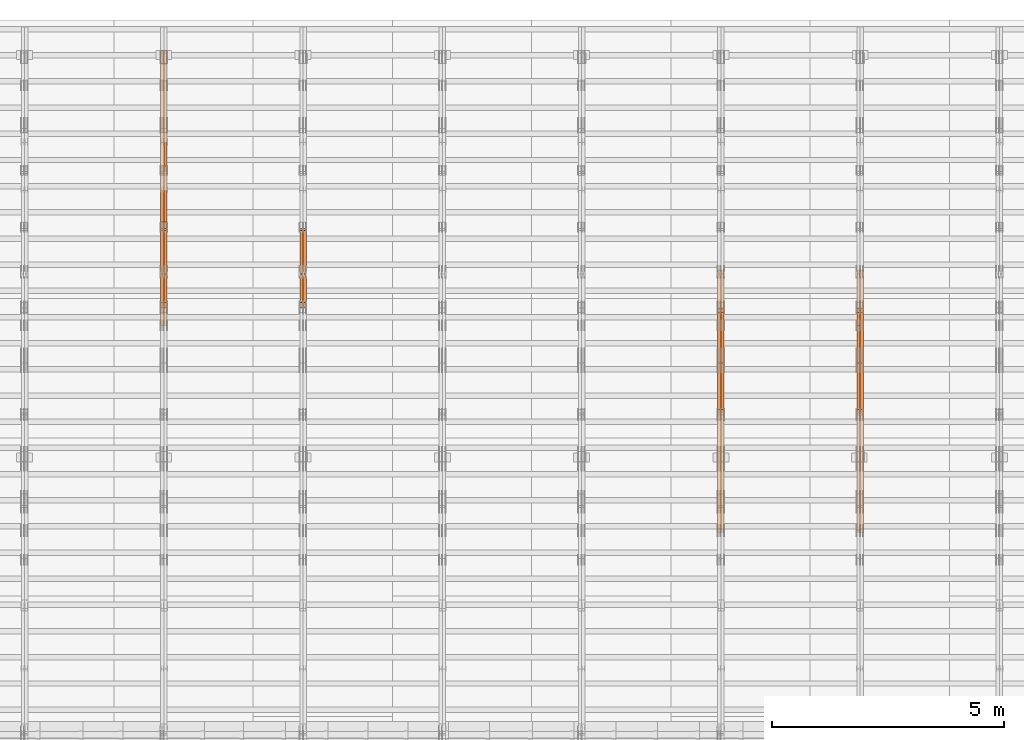
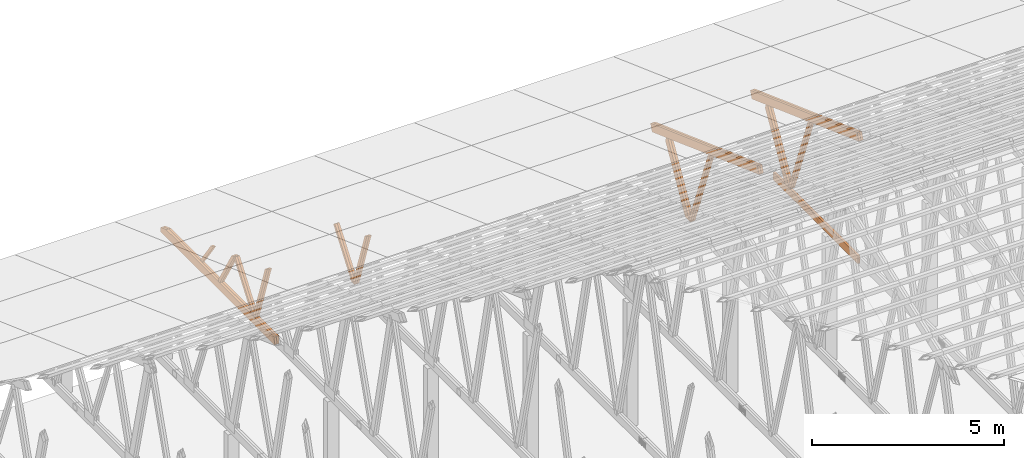
# One storey, part 42 of 189: 26 proxies.
"""IFC2X3 building model written with IfcOpenShell, lengths in millimetres."""

import ifcopenshell
import ifcopenshell.guid

model = None  # the IFC model being written
_history = None  # IfcOwnerHistory: only IFC2X3 demands one
_inside = {}  # id of a spatial element -> (the spatial element, [elements in it])
_under = {}  # id of a project, library or spatial element -> (it, [spatial elements below it])
_declared = {}  # id of a project -> (the project, [libraries it declares])
_typed = {}  # id of a type object -> (the type object, [elements of that type])
_made_of = {}  # id of a material, layer set ... -> (it, [elements and type objects made of it])


def new_model(schema):
    """Start an empty IFC model of exactly this schema.

    Asked for "IFC4X3", IfcOpenShell would pick the latest addendum, in which some entities
    have other attributes; the version numbers below select the first issue.
    IFC2X3 requires an IfcOwnerHistory on every rooted entity: one is made here for all.
    """
    global model, _history
    if schema == "IFC4X3":
        model = ifcopenshell.file(schema_version=(4, 3, 0, 0))
    else:
        model = ifcopenshell.file(schema=schema)
    _inside.clear()
    _under.clear()
    _declared.clear()
    _typed.clear()
    _made_of.clear()
    _history = None
    if model.schema == "IFC2X3":
        org = make("IfcOrganization", Name="unknown")
        user = make(
            "IfcPersonAndOrganization",
            ThePerson=make("IfcPerson", FamilyName="unknown"),
            TheOrganization=org,
        )
        app = make(
            "IfcApplication",
            ApplicationDeveloper=org,
            Version="unknown",
            ApplicationFullName="unknown",
            ApplicationIdentifier="unknown",
        )
        _history = make(
            "IfcOwnerHistory",
            OwningUser=user,
            OwningApplication=app,
            ChangeAction="ADDED",
            CreationDate=0,
        )
    return model


def make(cls, **values):
    """One entity of the class cls with the attributes given. An attribute that is None is left unset."""
    return model.create_entity(
        cls, **{name: value for name, value in values.items() if value is not None}
    )


def entity(cls, *values):
    """Any entity or typed value of the class cls, its attributes in the order of the schema. None: left unset."""
    e = model.create_entity(cls)
    for i, value in enumerate(values):
        if value is not None:
            e[i] = value
    return e


def rooted(cls, **values):
    """An entity with a GlobalId (a new one), such as an element, a storey or a relation."""
    return make(cls, GlobalId=ifcopenshell.guid.new(), OwnerHistory=_history, **values)


def si_unit(unit_type, name, prefix=None):
    """IfcSIUnit, for example si_unit("LENGTHUNIT", "METRE", prefix="MILLI")."""
    return make("IfcSIUnit", UnitType=unit_type, Prefix=prefix, Name=name)


def converted_unit(unit_type, name, factor, base, dimensions=None, offset=None):
    """IfcConversionBasedUnit, such as the inch: factor (a typed value) times the base unit."""
    return make(
        "IfcConversionBasedUnit"
        if offset is None
        else "IfcConversionBasedUnitWithOffset",
        ConversionOffset=offset,
        Dimensions=None
        if dimensions is None
        else entity("IfcDimensionalExponents", *dimensions),
        UnitType=unit_type,
        Name=name,
        ConversionFactor=make(
            "IfcMeasureWithUnit", ValueComponent=factor, UnitComponent=base
        ),
    )


def derived_unit(unit_type, elements):
    """IfcDerivedUnit: a product of units, each with its exponent."""
    return make(
        "IfcDerivedUnit",
        Elements=[
            make("IfcDerivedUnitElement", Unit=unit, Exponent=power)
            for unit, power in elements
        ],
        UnitType=unit_type,
    )


def assignment(units):
    """IfcUnitAssignment: the units of a project."""
    return None if units is None else make("IfcUnitAssignment", Units=units)


def point(xyz):
    """IfcCartesianPoint."""
    return None if xyz is None else make("IfcCartesianPoint", Coordinates=xyz)


def direction(xyz):
    """IfcDirection."""
    return None if xyz is None else make("IfcDirection", DirectionRatios=xyz)


def frame(location, z_axis=None, x_axis=None):
    """IfcAxis2Placement3D, a coordinate frame: its origin and axes. An axis left out is left unset."""
    return make(
        "IfcAxis2Placement3D",
        Location=point(location),
        Axis=direction(z_axis),
        RefDirection=direction(x_axis),
    )


def frame_2d(location, x_axis=None):
    """IfcAxis2Placement2D, a coordinate frame in the plane: its origin and x axis."""
    return make(
        "IfcAxis2Placement2D", Location=point(location), RefDirection=direction(x_axis)
    )


def origin():
    """The frame at (0, 0, 0) with its axes left unset."""
    return frame((0.0, 0.0, 0.0))


def origin_2d_with_axis():
    """The frame at (0, 0) in the plane with the x axis (1, 0) written out."""
    return frame_2d((0.0, 0.0), x_axis=(1.0, 0.0))


def place(relative_to, where):
    """IfcLocalPlacement: puts the frame where relative to a parent placement (None: the world)."""
    return make(
        "IfcLocalPlacement", PlacementRelTo=relative_to, RelativePlacement=where
    )


def context(
    kind, dimensions, precision=None, world=None, true_north=None, identifier=None
):
    """IfcGeometricRepresentationContext, for example the 3D "Model" context."""
    return make(
        "IfcGeometricRepresentationContext",
        ContextIdentifier=identifier,
        ContextType=kind,
        CoordinateSpaceDimension=dimensions,
        Precision=precision,
        WorldCoordinateSystem=world,
        TrueNorth=true_north,
    )


def subcontext(parent, identifier, kind, view, scale=None):
    """IfcGeometricRepresentationSubContext, for example "Body" below "Model"."""
    return make(
        "IfcGeometricRepresentationSubContext",
        ContextIdentifier=identifier,
        ContextType=kind,
        ParentContext=parent,
        TargetScale=scale,
        TargetView=view,
    )


def project(units=None, contexts=None):
    """IfcProject with its units and contexts."""
    return rooted(
        "IfcProject",
        Name="project",
        RepresentationContexts=contexts,
        UnitsInContext=assignment(units),
    )


def spatial(cls, under=None, at=None, **own):
    """A site, building, storey or space (cls), placed at a placement, below another one or the project."""
    s = rooted(cls, ObjectPlacement=at, **own)
    if under is not None:
        _under.setdefault(under.id(), (under, []))[1].append(s)
    return s


def polyline(points):
    """IfcPolyline through the points."""
    return make("IfcPolyline", Points=[point(p) for p in points])


def profile(cls, at=None, kind="AREA", **sizes):
    """A parametric profile (cls). Its sizes go by their IFC names, for example OverallWidth=200.0."""
    return make(cls, ProfileType=kind, Position=at, **sizes)


def rectangle(**sizes):
    """IfcRectangleProfileDef."""
    return profile("IfcRectangleProfileDef", **sizes)


def outline(outer, holes=None, kind="AREA"):
    """IfcArbitraryClosedProfileDef: a profile drawn as a closed curve; with holes, ...WithVoids."""
    if holes is None:
        return make("IfcArbitraryClosedProfileDef", ProfileType=kind, OuterCurve=outer)
    return make(
        "IfcArbitraryProfileDefWithVoids",
        ProfileType=kind,
        OuterCurve=outer,
        InnerCurves=holes,
    )


def extrude(swept, where, along, depth):
    """IfcExtrudedAreaSolid: the profile swept, set in the frame where, extruded along a direction by depth."""
    return make(
        "IfcExtrudedAreaSolid",
        SweptArea=swept,
        Position=where,
        ExtrudedDirection=direction(along),
        Depth=depth,
    )


def shape(context_of_items, identifier, shape_type, items):
    """IfcShapeRepresentation: the items that make up one representation, for example the "Body"."""
    return make(
        "IfcShapeRepresentation",
        ContextOfItems=context_of_items,
        RepresentationIdentifier=identifier,
        RepresentationType=shape_type,
        Items=items,
    )


def source(mapping_origin, context_of_items, identifier, shape_type, items):
    """IfcRepresentationMap: a shape defined once, which mapped items show again and again."""
    return make(
        "IfcRepresentationMap",
        MappingOrigin=mapping_origin,
        MappedRepresentation=shape(context_of_items, identifier, shape_type, items),
    )


def transform(
    local_origin,
    x_axis=None,
    y_axis=None,
    z_axis=None,
    scale=None,
    scale2=None,
    scale3=None,
    uniform=True,
):
    """IfcCartesianTransformationOperator3D, or its non-uniform kind. x_axis, y_axis, z_axis: its Axis1, 2, 3."""
    if uniform:
        return make(
            "IfcCartesianTransformationOperator3D",
            Axis1=direction(x_axis),
            Axis2=direction(y_axis),
            LocalOrigin=point(local_origin),
            Scale=scale,
            Axis3=direction(z_axis),
        )
    return make(
        "IfcCartesianTransformationOperator3DnonUniform",
        Axis1=direction(x_axis),
        Axis2=direction(y_axis),
        LocalOrigin=point(local_origin),
        Scale=scale,
        Axis3=direction(z_axis),
        Scale2=scale2,
        Scale3=scale3,
    )


def mapped(mapping_source, mapping_target):
    """IfcMappedItem: shows the shape of a source again, moved by a transform."""
    return make(
        "IfcMappedItem", MappingSource=mapping_source, MappingTarget=mapping_target
    )


def material(Name=None, Category=None):
    """IfcMaterial."""
    return make("IfcMaterial", Name=Name, Category=Category)


def made_of(thing, what):
    """Note that an element or type object is made of a material, layer set ...; save() writes the relation."""
    if what is not None:
        _made_of.setdefault(what.id(), (what, []))[1].append(thing)
    return thing


def type_object(cls, material=None, **own):
    """A type object (cls), such as IfcWallType, which elements share."""
    return made_of(rooted(cls, **own), material)


def type_shapes(of_type, sources):
    """Give a type object the sources (RepresentationMaps) that its elements show as mapped items."""
    of_type.RepresentationMaps = sources


def element(
    cls,
    number,
    at=None,
    inside=None,
    cuts=None,
    type_object=None,
    material=None,
    context=None,
    identifier="Body",
    shape_type=None,
    held_by="IfcProductDefinitionShape",
    body=None,
    shapes=None,
    **own,
):
    """One element of the class cls, such as IfcWall. Its Tag is "e" and its number.

    at: its placement. inside: the storey or other place that contains it. cuts: it is an
    opening in that element (IfcRelVoidsElement). A single representation is given by context,
    identifier, shape_type and body (its items); several are given by shapes. held_by: the class
    of the entity that holds the representations. save() writes the other relations.
    """
    e = rooted(cls, Tag="e%d" % number, ObjectPlacement=at, **own)
    if body is not None:
        shapes = [shape(context, identifier, shape_type, body)]
    if shapes is not None:
        e.Representation = make(held_by, Representations=shapes)
    if inside is not None:
        _inside.setdefault(inside.id(), (inside, []))[1].append(e)
    if cuts is not None:
        rooted(
            "IfcRelVoidsElement", RelatingBuildingElement=cuts, RelatedOpeningElement=e
        )
    if type_object is not None:
        _typed.setdefault(type_object.id(), (type_object, []))[1].append(e)
    return made_of(e, material)


def aggregate(whole, parts):
    """IfcRelAggregates: a whole, such as a stair, and the parts it consists of."""
    return rooted("IfcRelAggregates", RelatingObject=whole, RelatedObjects=parts)


def save(model, path):
    """Write the relations noted so far, then the file.

    IfcRelAggregates (storeys below a building ...), IfcRelContainedInSpatialStructure (elements
    in a storey), IfcRelDefinesByType, IfcRelAssociatesMaterial and IfcRelDeclares: one each for
    every whole, place, type object, material and project.
    """
    for whole, parts in _under.values():
        aggregate(whole, parts)
    for where, things in _inside.values():
        rooted(
            "IfcRelContainedInSpatialStructure",
            RelatedElements=things,
            RelatingStructure=where,
        )
    for kind, things in _typed.values():
        rooted("IfcRelDefinesByType", RelatedObjects=things, RelatingType=kind)
    for what, things in _made_of.values():
        rooted("IfcRelAssociatesMaterial", RelatedObjects=things, RelatingMaterial=what)
    for by, libraries in _declared.values():
        rooted("IfcRelDeclares", RelatingContext=by, RelatedDefinitions=libraries)
    model.write(path)


model = new_model("IFC2X3")

# Units and contexts
model_context = context("Model", 3, precision=0.01, world=origin(), true_north=direction((6.12303176911189e-17, 1.0)))
body_context = subcontext(model_context, "Body", "Model", "MODEL_VIEW")
ifc_project = project(units=[si_unit("LENGTHUNIT", "METRE", prefix="MILLI"), si_unit("AREAUNIT", "SQUARE_METRE"), si_unit("VOLUMEUNIT", "CUBIC_METRE"), converted_unit("PLANEANGLEUNIT", "DEGREE", entity("IfcRatioMeasure", 0.0174532925199433), si_unit("PLANEANGLEUNIT", "RADIAN"), dimensions=[0, 0, 0, 0, 0, 0, 0]), si_unit("MASSUNIT", "GRAM", prefix="KILO"), derived_unit("MASSDENSITYUNIT", [(si_unit("MASSUNIT", "GRAM", prefix="KILO"), 1), (si_unit("LENGTHUNIT", "METRE"), -3)]), si_unit("TIMEUNIT", "SECOND"), si_unit("FREQUENCYUNIT", "HERTZ"), si_unit("THERMODYNAMICTEMPERATUREUNIT", "DEGREE_CELSIUS"), derived_unit("THERMALTRANSMITTANCEUNIT", [(si_unit("MASSUNIT", "GRAM", prefix="KILO"), 1), (si_unit("THERMODYNAMICTEMPERATUREUNIT", "KELVIN"), -1), (si_unit("TIMEUNIT", "SECOND"), -3)]), derived_unit("VOLUMETRICFLOWRATEUNIT", [(si_unit("LENGTHUNIT", "METRE"), 3), (si_unit("TIMEUNIT", "SECOND"), -1)]), si_unit("ELECTRICCURRENTUNIT", "AMPERE"), si_unit("ELECTRICVOLTAGEUNIT", "VOLT"), si_unit("POWERUNIT", "WATT"), si_unit("FORCEUNIT", "NEWTON"), si_unit("ILLUMINANCEUNIT", "LUX"), si_unit("LUMINOUSFLUXUNIT", "LUMEN"), si_unit("LUMINOUSINTENSITYUNIT", "CANDELA"), derived_unit("USERDEFINED", [(si_unit("MASSUNIT", "GRAM", prefix="KILO"), -1), (si_unit("LENGTHUNIT", "METRE"), -2), (si_unit("TIMEUNIT", "SECOND"), 3), (si_unit("LUMINOUSFLUXUNIT", "LUMEN"), 1)]), derived_unit("LINEARVELOCITYUNIT", [(si_unit("LENGTHUNIT", "METRE"), 1), (si_unit("TIMEUNIT", "SECOND"), -1)]), si_unit("PRESSUREUNIT", "PASCAL"), derived_unit("USERDEFINED", [(si_unit("LENGTHUNIT", "METRE"), -2), (si_unit("MASSUNIT", "GRAM", prefix="KILO"), 1), (si_unit("TIMEUNIT", "SECOND"), -2)])], contexts=[model_context])

# Site, building, storey
site_placement = place(None, origin())
site = spatial("IfcSite", under=ifc_project, at=site_placement, CompositionType="ELEMENT")
building_placement = place(site_placement, origin())
building = spatial("IfcBuilding", under=site, at=building_placement, CompositionType="ELEMENT")
storey_placement = place(building_placement, origin())
storey = spatial("IfcBuildingStorey", under=building, at=storey_placement, Name="Default", CompositionType="ELEMENT", Elevation=0.0)

# Proxies
ifc_material_1 = material(Name="IfcSurfaceStyle #161658")
building_element_proxy_type_1 = type_object("IfcBuildingElementProxyType", Name="T1-W8 161656", PredefinedType="NOTDEFINED", material=ifc_material_1)
shared_shape_1 = source(origin(), body_context, "Body", "SweptSolid", [
    extrude(outline(polyline([(-1700.10906247918, -47.4998559987011), (1140.60243146647, -47.4998559987011), (1179.56122089033, 0.000120838919977206), (1161.65086478184, 47.4997955792411), (-1781.70545465947, 47.4997955792411), (-1700.10906247918, -47.4998559987011)])), frame((1179.56128464708, 47.5000634692093, 0.0), z_axis=(0.0, 0.0, 1.0), x_axis=(-1.0, 0.0, 0.0)), (0.0, 0.0, 1.0), 69.9999999999998),
])
type_shapes(building_element_proxy_type_1, [shared_shape_1])
proxy_1_placement = place(building_placement, frame((30300.0, 22687.5385403115, 228.241249073207), z_axis=(-1.0, 0.0, 0.0), x_axis=(0.0, -0.352814979177604, 0.93569310698963)))
element("IfcBuildingElementProxy", 1, at=proxy_1_placement, inside=storey, type_object=building_element_proxy_type_1, material=ifc_material_1, Name="T1-W8", context=body_context, shape_type="MappedRepresentation", body=[
    mapped(shared_shape_1, transform((0.0, 0.0, 0.0), scale=1.0)),
])
ifc_material_2 = material(Name="IfcSurfaceStyle #161592")
building_element_proxy_type_2 = type_object("IfcBuildingElementProxyType", Name="T1-W8 161590", PredefinedType="NOTDEFINED", material=ifc_material_2)
shared_shape_2 = source(origin(), body_context, "Body", "SweptSolid", [
    extrude(outline(polyline([(-1700.10906247918, -47.4998559987011), (1140.60243146647, -47.4998559987011), (1179.56122089033, 0.000120838919977206), (1161.65086478184, 47.4997955792411), (-1781.70545465947, 47.4997955792411), (-1700.10906247918, -47.4998559987011)])), frame((1179.56128464708, 47.5000634692093, 0.0), z_axis=(0.0, 0.0, 1.0), x_axis=(-1.0, 0.0, 0.0)), (0.0, 0.0, 1.0), 69.9999999999998),
])
type_shapes(building_element_proxy_type_2, [shared_shape_2])
proxy_2_placement = place(building_placement, frame((30230.0, 22687.5385403115, 228.241249073207), z_axis=(-1.0, 0.0, 0.0), x_axis=(0.0, -0.352814979177604, 0.93569310698963)))
element("IfcBuildingElementProxy", 2, at=proxy_2_placement, inside=storey, type_object=building_element_proxy_type_2, material=ifc_material_2, Name="T1-W8", context=body_context, shape_type="MappedRepresentation", body=[
    mapped(shared_shape_2, transform((0.0, 0.0, 0.0), scale=1.0)),
])
ifc_material_3 = material(Name="IfcSurfaceStyle #161394")
building_element_proxy_type_3 = type_object("IfcBuildingElementProxyType", Name="T1-W2 161392", PredefinedType="NOTDEFINED", material=ifc_material_3)
shared_shape_3 = source(origin(), body_context, "Body", "SweptSolid", [
    extrude(outline(polyline([(-1361.89144606429, -97.5000598486876), (887.613245225805, -97.5000598486876), (904.774262962339, 0.000302345139042259), (818.892339969004, 97.4999086761182), (-1249.38840209286, 97.4999086761182), (-1361.89144606429, -97.5000598486876)])), frame((904.774262962339, 97.5000966763391, 0.0), z_axis=(0.0, 0.0, 1.0), x_axis=(-1.0, 0.0, 0.0)), (0.0, 0.0, 1.0), 69.9999999999999),
])
type_shapes(building_element_proxy_type_3, [shared_shape_3])
proxy_3_placement = place(building_placement, frame((30300.0, 24033.6159173732, 2110.89189244614), z_axis=(-1.0, 0.0, 0.0), x_axis=(0.0, -0.5, -0.866025403784439)))
element("IfcBuildingElementProxy", 3, at=proxy_3_placement, inside=storey, type_object=building_element_proxy_type_3, material=ifc_material_3, Name="T1-W2", context=body_context, shape_type="MappedRepresentation", body=[
    mapped(shared_shape_3, transform((0.0, 0.0, 0.0), scale=1.0)),
])
ifc_material_4 = material(Name="IfcSurfaceStyle #161328")
building_element_proxy_type_4 = type_object("IfcBuildingElementProxyType", Name="T1-W2 161326", PredefinedType="NOTDEFINED", material=ifc_material_4)
shared_shape_4 = source(origin(), body_context, "Body", "SweptSolid", [
    extrude(outline(polyline([(-1361.89144606429, -97.5000598486876), (887.613245225805, -97.5000598486876), (904.774262962339, 0.000302345139042259), (818.892339969004, 97.4999086761182), (-1249.38840209286, 97.4999086761182), (-1361.89144606429, -97.5000598486876)])), frame((904.774262962339, 97.5000966763391, 0.0), z_axis=(0.0, 0.0, 1.0), x_axis=(-1.0, 0.0, 0.0)), (0.0, 0.0, 1.0), 69.9999999999999),
])
type_shapes(building_element_proxy_type_4, [shared_shape_4])
proxy_4_placement = place(building_placement, frame((30230.0, 24033.6159173732, 2110.89189244614), z_axis=(-1.0, 0.0, 0.0), x_axis=(0.0, -0.5, -0.866025403784439)))
element("IfcBuildingElementProxy", 4, at=proxy_4_placement, inside=storey, type_object=building_element_proxy_type_4, material=ifc_material_4, Name="T1-W2", context=body_context, shape_type="MappedRepresentation", body=[
    mapped(shared_shape_4, transform((0.0, 0.0, 0.0), scale=1.0)),
])
ifc_material_5 = material(Name="IfcSurfaceStyle #159261")
building_element_proxy_type_5 = type_object("IfcBuildingElementProxyType", Name="T1-B4 159259", PredefinedType="NOTDEFINED", material=ifc_material_5)
shared_shape_5 = source(origin(), body_context, "Body", "SweptSolid", [
    extrude(rectangle(XDim=4408.2412109375, YDim=245.000000000001, at=origin_2d_with_axis()), frame((2204.12060546875, 122.5, 0.0), z_axis=(0.0, 0.0, 1.0), x_axis=(-1.0, 0.0, 0.0)), (0.0, 0.0, 1.0), 69.9999999999997),
])
type_shapes(building_element_proxy_type_5, [shared_shape_5])
proxy_5_placement = place(building_placement, frame((30230.0, 19161.7587890625, 245.0), z_axis=(-1.0, 0.0, 0.0), x_axis=(0.0, 1.0, 0.0)))
element("IfcBuildingElementProxy", 5, at=proxy_5_placement, inside=storey, type_object=building_element_proxy_type_5, material=ifc_material_5, Name="T1-B4", context=body_context, shape_type="MappedRepresentation", body=[
    mapped(shared_shape_5, transform((0.0, 0.0, 0.0), scale=1.0)),
])
ifc_material_6 = material(Name="IfcSurfaceStyle #158274")
building_element_proxy_type_6 = type_object("IfcBuildingElementProxyType", Name="T1-T1 158272", PredefinedType="NOTDEFINED", material=ifc_material_6)
shared_shape_6 = source(origin(), body_context, "Body", "SweptSolid", [
    extrude(outline(polyline([(-2964.99982426074, -122.499947708046), (2964.99981923522, -122.499947708046), (2964.99984513599, 122.499947708046), (-2964.99984011047, 122.499947708046), (-2964.99982426074, -122.499947708046)])), frame((2964.99984513599, 122.499998966405, 0.0), z_axis=(0.0, 0.0, 1.0), x_axis=(-1.0, 0.0, 0.0)), (0.0, 0.0, 1.0), 69.9999999999996),
])
type_shapes(building_element_proxy_type_6, [shared_shape_6])
proxy_6_placement = place(building_placement, frame((30300.0, 24681.3398262186, 1893.12531804384), z_axis=(-1.0, 0.0, 0.0), x_axis=(0.0, -0.939692620785908, 0.342020143325669)))
element("IfcBuildingElementProxy", 6, at=proxy_6_placement, inside=storey, type_object=building_element_proxy_type_6, material=ifc_material_6, Name="T1-T1", context=body_context, shape_type="MappedRepresentation", body=[
    mapped(shared_shape_6, transform((0.0, 0.0, 0.0), scale=1.0)),
])
ifc_material_7 = material(Name="IfcSurfaceStyle #158217")
building_element_proxy_type_7 = type_object("IfcBuildingElementProxyType", Name="T1-T1 158215", PredefinedType="NOTDEFINED", material=ifc_material_7)
shared_shape_7 = source(origin(), body_context, "Body", "SweptSolid", [
    extrude(outline(polyline([(-2964.99982426074, -122.499947708046), (2964.99981923522, -122.499947708046), (2964.99984513599, 122.499947708046), (-2964.99984011047, 122.499947708046), (-2964.99982426074, -122.499947708046)])), frame((2964.99984513599, 122.499998966405, 0.0), z_axis=(0.0, 0.0, 1.0), x_axis=(-1.0, 0.0, 0.0)), (0.0, 0.0, 1.0), 69.9999999999996),
])
type_shapes(building_element_proxy_type_7, [shared_shape_7])
proxy_7_placement = place(building_placement, frame((30230.0, 24681.3398262186, 1893.12531804384), z_axis=(-1.0, 0.0, 0.0), x_axis=(0.0, -0.939692620785908, 0.342020143325669)))
element("IfcBuildingElementProxy", 7, at=proxy_7_placement, inside=storey, type_object=building_element_proxy_type_7, material=ifc_material_7, Name="T1-T1", context=body_context, shape_type="MappedRepresentation", body=[
    mapped(shared_shape_7, transform((0.0, 0.0, 0.0), scale=1.0)),
])
ifc_material_8 = material(Name="IfcSurfaceStyle #145868")
building_element_proxy_type_8 = type_object("IfcBuildingElementProxyType", Name="T1-W8 145866", PredefinedType="NOTDEFINED", material=ifc_material_8)
shared_shape_8 = source(origin(), body_context, "Body", "SweptSolid", [
    extrude(outline(polyline([(-1700.10906247918, -47.4998559987011), (1140.60243146647, -47.4998559987011), (1179.56122089033, 0.000120838919977206), (1161.65086478184, 47.4997955792411), (-1781.70545465947, 47.4997955792411), (-1700.10906247918, -47.4998559987011)])), frame((1179.56128464708, 47.5000634692093, 0.0), z_axis=(0.0, 0.0, 1.0), x_axis=(-1.0, 0.0, 0.0)), (0.0, 0.0, 1.0), 69.9999999999998),
])
type_shapes(building_element_proxy_type_8, [shared_shape_8])
proxy_8_placement = place(building_placement, frame((27300.0, 22687.5385403115, 228.241249073207), z_axis=(-1.0, 0.0, 0.0), x_axis=(0.0, -0.352814979177604, 0.93569310698963)))
element("IfcBuildingElementProxy", 8, at=proxy_8_placement, inside=storey, type_object=building_element_proxy_type_8, material=ifc_material_8, Name="T1-W8", context=body_context, shape_type="MappedRepresentation", body=[
    mapped(shared_shape_8, transform((0.0, 0.0, 0.0), scale=1.0)),
])
ifc_material_9 = material(Name="IfcSurfaceStyle #145802")
building_element_proxy_type_9 = type_object("IfcBuildingElementProxyType", Name="T1-W8 145800", PredefinedType="NOTDEFINED", material=ifc_material_9)
shared_shape_9 = source(origin(), body_context, "Body", "SweptSolid", [
    extrude(outline(polyline([(-1700.10906247918, -47.4998559987011), (1140.60243146647, -47.4998559987011), (1179.56122089033, 0.000120838919977206), (1161.65086478184, 47.4997955792411), (-1781.70545465947, 47.4997955792411), (-1700.10906247918, -47.4998559987011)])), frame((1179.56128464708, 47.5000634692093, 0.0), z_axis=(0.0, 0.0, 1.0), x_axis=(-1.0, 0.0, 0.0)), (0.0, 0.0, 1.0), 69.9999999999998),
])
type_shapes(building_element_proxy_type_9, [shared_shape_9])
proxy_9_placement = place(building_placement, frame((27230.0, 22687.5385403115, 228.241249073207), z_axis=(-1.0, 0.0, 0.0), x_axis=(0.0, -0.352814979177604, 0.93569310698963)))
element("IfcBuildingElementProxy", 9, at=proxy_9_placement, inside=storey, type_object=building_element_proxy_type_9, material=ifc_material_9, Name="T1-W8", context=body_context, shape_type="MappedRepresentation", body=[
    mapped(shared_shape_9, transform((0.0, 0.0, 0.0), scale=1.0)),
])
ifc_material_10 = material(Name="IfcSurfaceStyle #145604")
building_element_proxy_type_10 = type_object("IfcBuildingElementProxyType", Name="T1-W2 145602", PredefinedType="NOTDEFINED", material=ifc_material_10)
shared_shape_10 = source(origin(), body_context, "Body", "SweptSolid", [
    extrude(outline(polyline([(-1361.89144606429, -97.5000598486876), (887.613245225805, -97.5000598486876), (904.774262962339, 0.000302345139042259), (818.892339969004, 97.4999086761182), (-1249.38840209286, 97.4999086761182), (-1361.89144606429, -97.5000598486876)])), frame((904.774262962339, 97.5000966763391, 0.0), z_axis=(0.0, 0.0, 1.0), x_axis=(-1.0, 0.0, 0.0)), (0.0, 0.0, 1.0), 69.9999999999999),
])
type_shapes(building_element_proxy_type_10, [shared_shape_10])
proxy_10_placement = place(building_placement, frame((27300.0, 24033.6159173732, 2110.89189244614), z_axis=(-1.0, 0.0, 0.0), x_axis=(0.0, -0.5, -0.866025403784439)))
element("IfcBuildingElementProxy", 10, at=proxy_10_placement, inside=storey, type_object=building_element_proxy_type_10, material=ifc_material_10, Name="T1-W2", context=body_context, shape_type="MappedRepresentation", body=[
    mapped(shared_shape_10, transform((0.0, 0.0, 0.0), scale=1.0)),
])
ifc_material_11 = material(Name="IfcSurfaceStyle #145538")
building_element_proxy_type_11 = type_object("IfcBuildingElementProxyType", Name="T1-W2 145536", PredefinedType="NOTDEFINED", material=ifc_material_11)
shared_shape_11 = source(origin(), body_context, "Body", "SweptSolid", [
    extrude(outline(polyline([(-1361.89144606429, -97.5000598486876), (887.613245225805, -97.5000598486876), (904.774262962339, 0.000302345139042259), (818.892339969004, 97.4999086761182), (-1249.38840209286, 97.4999086761182), (-1361.89144606429, -97.5000598486876)])), frame((904.774262962339, 97.5000966763391, 0.0), z_axis=(0.0, 0.0, 1.0), x_axis=(-1.0, 0.0, 0.0)), (0.0, 0.0, 1.0), 69.9999999999999),
])
type_shapes(building_element_proxy_type_11, [shared_shape_11])
proxy_11_placement = place(building_placement, frame((27230.0, 24033.6159173732, 2110.89189244614), z_axis=(-1.0, 0.0, 0.0), x_axis=(0.0, -0.5, -0.866025403784439)))
element("IfcBuildingElementProxy", 11, at=proxy_11_placement, inside=storey, type_object=building_element_proxy_type_11, material=ifc_material_11, Name="T1-W2", context=body_context, shape_type="MappedRepresentation", body=[
    mapped(shared_shape_11, transform((0.0, 0.0, 0.0), scale=1.0)),
])
ifc_material_12 = material(Name="IfcSurfaceStyle #142484")
building_element_proxy_type_12 = type_object("IfcBuildingElementProxyType", Name="T1-T1 142482", PredefinedType="NOTDEFINED", material=ifc_material_12)
shared_shape_12 = source(origin(), body_context, "Body", "SweptSolid", [
    extrude(outline(polyline([(-2964.99982426074, -122.499947708046), (2964.99981923522, -122.499947708046), (2964.99984513599, 122.499947708046), (-2964.99984011047, 122.499947708046), (-2964.99982426074, -122.499947708046)])), frame((2964.99984513599, 122.499998966405, 0.0), z_axis=(0.0, 0.0, 1.0), x_axis=(-1.0, 0.0, 0.0)), (0.0, 0.0, 1.0), 69.9999999999996),
])
type_shapes(building_element_proxy_type_12, [shared_shape_12])
proxy_12_placement = place(building_placement, frame((27300.0, 24681.3398262186, 1893.12531804384), z_axis=(-1.0, 0.0, 0.0), x_axis=(0.0, -0.939692620785908, 0.342020143325669)))
element("IfcBuildingElementProxy", 12, at=proxy_12_placement, inside=storey, type_object=building_element_proxy_type_12, material=ifc_material_12, Name="T1-T1", context=body_context, shape_type="MappedRepresentation", body=[
    mapped(shared_shape_12, transform((0.0, 0.0, 0.0), scale=1.0)),
])
ifc_material_13 = material(Name="IfcSurfaceStyle #142427")
building_element_proxy_type_13 = type_object("IfcBuildingElementProxyType", Name="T1-T1 142425", PredefinedType="NOTDEFINED", material=ifc_material_13)
shared_shape_13 = source(origin(), body_context, "Body", "SweptSolid", [
    extrude(outline(polyline([(-2964.99982426074, -122.499947708046), (2964.99981923522, -122.499947708046), (2964.99984513599, 122.499947708046), (-2964.99984011047, 122.499947708046), (-2964.99982426074, -122.499947708046)])), frame((2964.99984513599, 122.499998966405, 0.0), z_axis=(0.0, 0.0, 1.0), x_axis=(-1.0, 0.0, 0.0)), (0.0, 0.0, 1.0), 69.9999999999996),
])
type_shapes(building_element_proxy_type_13, [shared_shape_13])
proxy_13_placement = place(building_placement, frame((27230.0, 24681.3398262186, 1893.12531804384), z_axis=(-1.0, 0.0, 0.0), x_axis=(0.0, -0.939692620785908, 0.342020143325669)))
element("IfcBuildingElementProxy", 13, at=proxy_13_placement, inside=storey, type_object=building_element_proxy_type_13, material=ifc_material_13, Name="T1-T1", context=body_context, shape_type="MappedRepresentation", body=[
    mapped(shared_shape_13, transform((0.0, 0.0, 0.0), scale=1.0)),
])
ifc_material_14 = material(Name="IfcSurfaceStyle #97970")
building_element_proxy_type_14 = type_object("IfcBuildingElementProxyType", Name="T1-W9 97968", PredefinedType="NOTDEFINED", material=ifc_material_14)
shared_shape_14 = source(origin(), body_context, "Body", "SweptSolid", [
    extrude(outline(polyline([(-1151.44310138162, -47.5000079487596), (776.329826327547, -47.5000079487596), (809.267611644053, -8.1966354137375e-07), (793.242530238244, 47.5000083585914), (-1227.39686682822, 47.5000083585914), (-1151.44310138162, -47.5000079487596)])), frame((809.267685789073, 47.5000083585914, 0.0), z_axis=(0.0, 0.0, 1.0), x_axis=(-1.0, 0.0, 0.0)), (0.0, 0.0, 1.0), 69.9999999999999),
])
type_shapes(building_element_proxy_type_14, [shared_shape_14])
proxy_14_placement = place(building_placement, frame((18300.0, 24600.2198992919, 229.815691184017), z_axis=(-1.0, 0.0, 0.0), x_axis=(0.0, -0.31966811847134, 0.947529574226047)))
element("IfcBuildingElementProxy", 14, at=proxy_14_placement, inside=storey, type_object=building_element_proxy_type_14, material=ifc_material_14, Name="T1-W9", context=body_context, shape_type="MappedRepresentation", body=[
    mapped(shared_shape_14, transform((0.0, 0.0, 0.0), scale=1.0)),
])
ifc_material_15 = material(Name="IfcSurfaceStyle #97904")
building_element_proxy_type_15 = type_object("IfcBuildingElementProxyType", Name="T1-W9 97902", PredefinedType="NOTDEFINED", material=ifc_material_15)
shared_shape_15 = source(origin(), body_context, "Body", "SweptSolid", [
    extrude(outline(polyline([(-1151.44310138162, -47.5000079487596), (776.329826327547, -47.5000079487596), (809.267611644053, -8.1966354137375e-07), (793.242530238244, 47.5000083585914), (-1227.39686682822, 47.5000083585914), (-1151.44310138162, -47.5000079487596)])), frame((809.267685789073, 47.5000083585914, 0.0), z_axis=(0.0, 0.0, 1.0), x_axis=(-1.0, 0.0, 0.0)), (0.0, 0.0, 1.0), 69.9999999999999),
])
type_shapes(building_element_proxy_type_15, [shared_shape_15])
proxy_15_placement = place(building_placement, frame((18230.0, 24600.2198992919, 229.815691184017), z_axis=(-1.0, 0.0, 0.0), x_axis=(0.0, -0.31966811847134, 0.947529574226047)))
element("IfcBuildingElementProxy", 15, at=proxy_15_placement, inside=storey, type_object=building_element_proxy_type_15, material=ifc_material_15, Name="T1-W9", context=body_context, shape_type="MappedRepresentation", body=[
    mapped(shared_shape_15, transform((0.0, 0.0, 0.0), scale=1.0)),
])
ifc_material_16 = material(Name="IfcSurfaceStyle #97706")
building_element_proxy_type_16 = type_object("IfcBuildingElementProxyType", Name="T1-W10 97704", PredefinedType="NOTDEFINED", material=ifc_material_16)
shared_shape_16 = source(origin(), body_context, "Body", "SweptSolid", [
    extrude(outline(polyline([(-993.240970354386, -47.5000757607337), (635.890952815036, -47.5000757607337), (650.068145237537, -1.47580554758164e-05), (629.921374092803, 47.5000831397614), (-922.639501790989, 47.5000831397614), (-993.240970354386, -47.5000757607337)])), frame((650.068173419645, 47.5002811208496, 0.0), z_axis=(0.0, 0.0, 1.0), x_axis=(-1.0, 0.0, 0.0)), (0.0, 0.0, 1.0), 69.9999999999999),
])
type_shapes(building_element_proxy_type_16, [shared_shape_16])
proxy_16_placement = place(building_placement, frame((18300.0, 25701.688098798, 1507.2920009025), z_axis=(-1.0, 0.0, 0.0), x_axis=(0.0, -0.596486092002004, -0.802623412347395)))
element("IfcBuildingElementProxy", 16, at=proxy_16_placement, inside=storey, type_object=building_element_proxy_type_16, material=ifc_material_16, Name="T1-W10", context=body_context, shape_type="MappedRepresentation", body=[
    mapped(shared_shape_16, transform((0.0, 0.0, 0.0), scale=1.0)),
])
ifc_material_17 = material(Name="IfcSurfaceStyle #97640")
building_element_proxy_type_17 = type_object("IfcBuildingElementProxyType", Name="T1-W10 97638", PredefinedType="NOTDEFINED", material=ifc_material_17)
shared_shape_17 = source(origin(), body_context, "Body", "SweptSolid", [
    extrude(outline(polyline([(-993.240970354386, -47.5000757607337), (635.890952815036, -47.5000757607337), (650.068145237537, -1.47580554758164e-05), (629.921374092803, 47.5000831397614), (-922.639501790989, 47.5000831397614), (-993.240970354386, -47.5000757607337)])), frame((650.068173419645, 47.5002811208496, 0.0), z_axis=(0.0, 0.0, 1.0), x_axis=(-1.0, 0.0, 0.0)), (0.0, 0.0, 1.0), 69.9999999999999),
])
type_shapes(building_element_proxy_type_17, [shared_shape_17])
proxy_17_placement = place(building_placement, frame((18230.0, 25701.688098798, 1507.2920009025), z_axis=(-1.0, 0.0, 0.0), x_axis=(0.0, -0.596486092002004, -0.802623412347395)))
element("IfcBuildingElementProxy", 17, at=proxy_17_placement, inside=storey, type_object=building_element_proxy_type_17, material=ifc_material_17, Name="T1-W10", context=body_context, shape_type="MappedRepresentation", body=[
    mapped(shared_shape_17, transform((0.0, 0.0, 0.0), scale=1.0)),
])
ifc_material_18 = material(Name="IfcSurfaceStyle #82180")
building_element_proxy_type_18 = type_object("IfcBuildingElementProxyType", Name="T1-W9 82178", PredefinedType="NOTDEFINED", material=ifc_material_18)
shared_shape_18 = source(origin(), body_context, "Body", "SweptSolid", [
    extrude(outline(polyline([(-1151.44310138162, -47.5000079487596), (776.329826327547, -47.5000079487596), (809.267611644053, -8.1966354137375e-07), (793.242530238244, 47.5000083585914), (-1227.39686682822, 47.5000083585914), (-1151.44310138162, -47.5000079487596)])), frame((809.267685789073, 47.5000083585914, 0.0), z_axis=(0.0, 0.0, 1.0), x_axis=(-1.0, 0.0, 0.0)), (0.0, 0.0, 1.0), 69.9999999999999),
])
type_shapes(building_element_proxy_type_18, [shared_shape_18])
proxy_18_placement = place(building_placement, frame((15300.0, 24600.2198992919, 229.815691184017), z_axis=(-1.0, 0.0, 0.0), x_axis=(0.0, -0.31966811847134, 0.947529574226047)))
element("IfcBuildingElementProxy", 18, at=proxy_18_placement, inside=storey, type_object=building_element_proxy_type_18, material=ifc_material_18, Name="T1-W9", context=body_context, shape_type="MappedRepresentation", body=[
    mapped(shared_shape_18, transform((0.0, 0.0, 0.0), scale=1.0)),
])
ifc_material_19 = material(Name="IfcSurfaceStyle #82114")
building_element_proxy_type_19 = type_object("IfcBuildingElementProxyType", Name="T1-W9 82112", PredefinedType="NOTDEFINED", material=ifc_material_19)
shared_shape_19 = source(origin(), body_context, "Body", "SweptSolid", [
    extrude(outline(polyline([(-1151.44310138162, -47.5000079487596), (776.329826327547, -47.5000079487596), (809.267611644053, -8.1966354137375e-07), (793.242530238244, 47.5000083585914), (-1227.39686682822, 47.5000083585914), (-1151.44310138162, -47.5000079487596)])), frame((809.267685789073, 47.5000083585914, 0.0), z_axis=(0.0, 0.0, 1.0), x_axis=(-1.0, 0.0, 0.0)), (0.0, 0.0, 1.0), 69.9999999999999),
])
type_shapes(building_element_proxy_type_19, [shared_shape_19])
proxy_19_placement = place(building_placement, frame((15230.0, 24600.2198992919, 229.815691184017), z_axis=(-1.0, 0.0, 0.0), x_axis=(0.0, -0.31966811847134, 0.947529574226047)))
element("IfcBuildingElementProxy", 19, at=proxy_19_placement, inside=storey, type_object=building_element_proxy_type_19, material=ifc_material_19, Name="T1-W9", context=body_context, shape_type="MappedRepresentation", body=[
    mapped(shared_shape_19, transform((0.0, 0.0, 0.0), scale=1.0)),
])
ifc_material_20 = material(Name="IfcSurfaceStyle #81916")
building_element_proxy_type_20 = type_object("IfcBuildingElementProxyType", Name="T1-W10 81914", PredefinedType="NOTDEFINED", material=ifc_material_20)
shared_shape_20 = source(origin(), body_context, "Body", "SweptSolid", [
    extrude(outline(polyline([(-993.240970354386, -47.5000757607337), (635.890952815036, -47.5000757607337), (650.068145237537, -1.47580554758164e-05), (629.921374092803, 47.5000831397614), (-922.639501790989, 47.5000831397614), (-993.240970354386, -47.5000757607337)])), frame((650.068173419645, 47.5002811208496, 0.0), z_axis=(0.0, 0.0, 1.0), x_axis=(-1.0, 0.0, 0.0)), (0.0, 0.0, 1.0), 69.9999999999999),
])
type_shapes(building_element_proxy_type_20, [shared_shape_20])
proxy_20_placement = place(building_placement, frame((15300.0, 25701.688098798, 1507.2920009025), z_axis=(-1.0, 0.0, 0.0), x_axis=(0.0, -0.596486092002004, -0.802623412347395)))
element("IfcBuildingElementProxy", 20, at=proxy_20_placement, inside=storey, type_object=building_element_proxy_type_20, material=ifc_material_20, Name="T1-W10", context=body_context, shape_type="MappedRepresentation", body=[
    mapped(shared_shape_20, transform((0.0, 0.0, 0.0), scale=1.0)),
])
ifc_material_21 = material(Name="IfcSurfaceStyle #81850")
building_element_proxy_type_21 = type_object("IfcBuildingElementProxyType", Name="T1-W10 81848", PredefinedType="NOTDEFINED", material=ifc_material_21)
shared_shape_21 = source(origin(), body_context, "Body", "SweptSolid", [
    extrude(outline(polyline([(-993.240970354386, -47.5000757607337), (635.890952815036, -47.5000757607337), (650.068145237537, -1.47580554758164e-05), (629.921374092803, 47.5000831397614), (-922.639501790989, 47.5000831397614), (-993.240970354386, -47.5000757607337)])), frame((650.068173419645, 47.5002811208496, 0.0), z_axis=(0.0, 0.0, 1.0), x_axis=(-1.0, 0.0, 0.0)), (0.0, 0.0, 1.0), 69.9999999999999),
])
type_shapes(building_element_proxy_type_21, [shared_shape_21])
proxy_21_placement = place(building_placement, frame((15230.0, 25701.688098798, 1507.2920009025), z_axis=(-1.0, 0.0, 0.0), x_axis=(0.0, -0.596486092002004, -0.802623412347395)))
element("IfcBuildingElementProxy", 21, at=proxy_21_placement, inside=storey, type_object=building_element_proxy_type_21, material=ifc_material_21, Name="T1-W10", context=body_context, shape_type="MappedRepresentation", body=[
    mapped(shared_shape_21, transform((0.0, 0.0, 0.0), scale=1.0)),
])
ifc_material_22 = material(Name="IfcSurfaceStyle #81652")
building_element_proxy_type_22 = type_object("IfcBuildingElementProxyType", Name="T1-W11 81650", PredefinedType="NOTDEFINED", material=ifc_material_22)
shared_shape_22 = source(origin(), body_context, "Body", "SweptSolid", [
    extrude(outline(polyline([(-809.410890003667, -47.5000077306544), (561.624013869753, -47.5000077306544), (599.944137054867, -7.52294285037536e-05), (572.078784657538, 47.5000453453687), (-924.236045578491, 47.5000453453687), (-809.410890003667, -47.5000077306544)])), frame((599.944137054867, 47.5000453453687, 0.0), z_axis=(0.0, 0.0, 1.0), x_axis=(-1.0, 0.0, 0.0)), (0.0, 0.0, 1.0), 69.9999999999999),
])
type_shapes(building_element_proxy_type_22, [shared_shape_22])
proxy_22_placement = place(building_placement, frame((15300.0, 26434.7921369083, 220.965133687368), z_axis=(-1.0, 0.0, 0.0), x_axis=(0.0, -0.505995901100603, 0.862535882192381)))
element("IfcBuildingElementProxy", 22, at=proxy_22_placement, inside=storey, type_object=building_element_proxy_type_22, material=ifc_material_22, Name="T1-W11", context=body_context, shape_type="MappedRepresentation", body=[
    mapped(shared_shape_22, transform((0.0, 0.0, 0.0), scale=1.0)),
])
ifc_material_23 = material(Name="IfcSurfaceStyle #81586")
building_element_proxy_type_23 = type_object("IfcBuildingElementProxyType", Name="T1-W11 81584", PredefinedType="NOTDEFINED", material=ifc_material_23)
shared_shape_23 = source(origin(), body_context, "Body", "SweptSolid", [
    extrude(outline(polyline([(-809.410890003667, -47.5000077306544), (561.624013869753, -47.5000077306544), (599.944137054867, -7.52294285037536e-05), (572.078784657538, 47.5000453453687), (-924.236045578491, 47.5000453453687), (-809.410890003667, -47.5000077306544)])), frame((599.944137054867, 47.5000453453687, 0.0), z_axis=(0.0, 0.0, 1.0), x_axis=(-1.0, 0.0, 0.0)), (0.0, 0.0, 1.0), 69.9999999999999),
])
type_shapes(building_element_proxy_type_23, [shared_shape_23])
proxy_23_placement = place(building_placement, frame((15230.0, 26434.7921369083, 220.965133687368), z_axis=(-1.0, 0.0, 0.0), x_axis=(0.0, -0.505995901100603, 0.862535882192381)))
element("IfcBuildingElementProxy", 23, at=proxy_23_placement, inside=storey, type_object=building_element_proxy_type_23, material=ifc_material_23, Name="T1-W11", context=body_context, shape_type="MappedRepresentation", body=[
    mapped(shared_shape_23, transform((0.0, 0.0, 0.0), scale=1.0)),
])
ifc_material_24 = material(Name="IfcSurfaceStyle #81124")
building_element_proxy_type_24 = type_object("IfcBuildingElementProxyType", Name="T1-W13 81122", PredefinedType="NOTDEFINED", material=ifc_material_24)
shared_shape_24 = source(origin(), body_context, "Body", "SweptSolid", [
    extrude(outline(polyline([(-527.416466728212, -47.5000272833949), (387.658053197984, -47.5000272833949), (418.029495084182, -7.96824534414764e-06), (384.779443025059, 47.5000312675175), (-663.050524579013, 47.5000312675176), (-527.416466728212, -47.5000272833949)])), frame((418.029495084182, 47.5000671658844, 0.0), z_axis=(0.0, 0.0, 1.0), x_axis=(-1.0, 0.0, 0.0)), (0.0, 0.0, 1.0), 69.9999999999999),
])
type_shapes(building_element_proxy_type_24, [shared_shape_24])
proxy_24_placement = place(building_placement, frame((15300.0, 27471.0085508293, 217.760482033818), z_axis=(-1.0, 0.0, 0.0), x_axis=(0.0, -0.573462629043498, 0.819231721242848)))
element("IfcBuildingElementProxy", 24, at=proxy_24_placement, inside=storey, type_object=building_element_proxy_type_24, material=ifc_material_24, Name="T1-W13", context=body_context, shape_type="MappedRepresentation", body=[
    mapped(shared_shape_24, transform((0.0, 0.0, 0.0), scale=1.0)),
])
ifc_material_25 = material(Name="IfcSurfaceStyle #80500")
building_element_proxy_type_25 = type_object("IfcBuildingElementProxyType", Name="T1-B1 80498", PredefinedType="NOTDEFINED", material=ifc_material_25)
shared_shape_25 = source(origin(), body_context, "Body", "SweptSolid", [
    extrude(outline(polyline([(-2430.09461669922, -125.855288696288), (3499.90538330078, -125.855288696288), (3499.90538330078, 119.144711303711), (-2139.62153320312, 119.144711303711), (-2430.09461669922, 13.4211547851552), (-2430.09461669922, -125.855288696288)])), frame((3499.90538330078, 119.144711303711, 0.0), z_axis=(0.0, 0.0, 1.0), x_axis=(-1.0, 0.0, 0.0)), (0.0, 0.0, 1.0), 69.9999999999996),
])
type_shapes(building_element_proxy_type_25, [shared_shape_25])
proxy_25_placement = place(building_placement, frame((15300.0, 23570.0, 245.0), z_axis=(-1.0, 0.0, 0.0), x_axis=(0.0, 1.0, 0.0)))
element("IfcBuildingElementProxy", 25, at=proxy_25_placement, inside=storey, type_object=building_element_proxy_type_25, material=ifc_material_25, Name="T1-B1", context=body_context, shape_type="MappedRepresentation", body=[
    mapped(shared_shape_25, transform((0.0, 0.0, 0.0), scale=1.0)),
])
ifc_material_26 = material(Name="IfcSurfaceStyle #80434")
building_element_proxy_type_26 = type_object("IfcBuildingElementProxyType", Name="T1-B1 80432", PredefinedType="NOTDEFINED", material=ifc_material_26)
shared_shape_26 = source(origin(), body_context, "Body", "SweptSolid", [
    extrude(outline(polyline([(-2430.09461669922, -125.855288696288), (3499.90538330078, -125.855288696288), (3499.90538330078, 119.144711303711), (-2139.62153320312, 119.144711303711), (-2430.09461669922, 13.4211547851552), (-2430.09461669922, -125.855288696288)])), frame((3499.90538330078, 119.144711303711, 0.0), z_axis=(0.0, 0.0, 1.0), x_axis=(-1.0, 0.0, 0.0)), (0.0, 0.0, 1.0), 69.9999999999996),
])
type_shapes(building_element_proxy_type_26, [shared_shape_26])
proxy_26_placement = place(building_placement, frame((15230.0, 23570.0, 245.0), z_axis=(-1.0, 0.0, 0.0), x_axis=(0.0, 1.0, 0.0)))
element("IfcBuildingElementProxy", 26, at=proxy_26_placement, inside=storey, type_object=building_element_proxy_type_26, material=ifc_material_26, Name="T1-B1", context=body_context, shape_type="MappedRepresentation", body=[
    mapped(shared_shape_26, transform((0.0, 0.0, 0.0), scale=1.0)),
])

save(model, "model.ifc")
